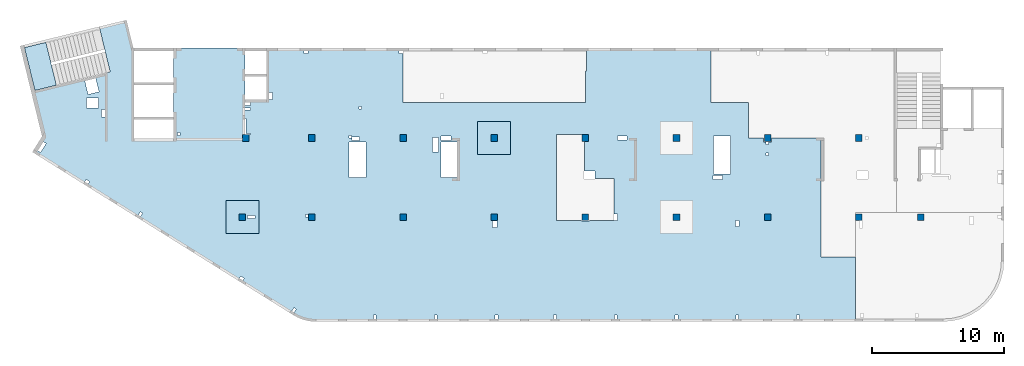
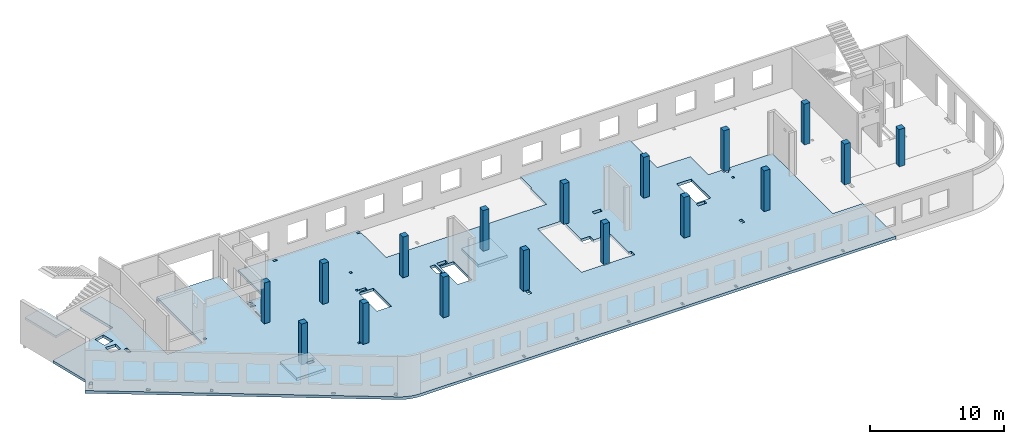
# One storey, part 1 of 6: 17 columns, 4 slabs.
"""IFC4 building model written with IfcOpenShell, lengths in millimetres."""

from ifc_helpers import new_model, entity, si_unit, converted_unit, derived_unit, direction, frame, origin, place, context, subcontext, project, spatial, indexed_curve, outline, extrude, source, transform, mapped, material, type_object, type_shapes, element, save


model = new_model("IFC4")

# Units and contexts
model_context = context("Model", 3, precision=0.01, world=origin(), true_north=direction((6.12303176911189e-17, 1.0)))
plan_context = context("Plan", 3, precision=0.01, world=origin(), true_north=direction((6.12303176911189e-17, 1.0)))
body_context = subcontext(model_context, "Body", "Model", "MODEL_VIEW")
ifc_project = project(units=[si_unit("LENGTHUNIT", "METRE", prefix="MILLI"), si_unit("AREAUNIT", "SQUARE_METRE"), si_unit("VOLUMEUNIT", "CUBIC_METRE"), converted_unit("PLANEANGLEUNIT", "DEGREE", entity("IfcRatioMeasure", 0.0174532925199433), si_unit("PLANEANGLEUNIT", "RADIAN"), dimensions=[0, 0, 0, 0, 0, 0, 0]), si_unit("MASSUNIT", "GRAM", prefix="KILO"), derived_unit("MASSDENSITYUNIT", [(si_unit("MASSUNIT", "GRAM", prefix="KILO"), 1), (si_unit("LENGTHUNIT", "METRE"), -3)]), derived_unit("MOMENTOFINERTIAUNIT", [(si_unit("LENGTHUNIT", "METRE"), 4)]), si_unit("TIMEUNIT", "SECOND"), si_unit("FREQUENCYUNIT", "HERTZ"), si_unit("THERMODYNAMICTEMPERATUREUNIT", "DEGREE_CELSIUS"), derived_unit("THERMALTRANSMITTANCEUNIT", [(si_unit("MASSUNIT", "GRAM", prefix="KILO"), 1), (si_unit("THERMODYNAMICTEMPERATUREUNIT", "KELVIN"), -1), (si_unit("TIMEUNIT", "SECOND"), -3)]), derived_unit("VOLUMETRICFLOWRATEUNIT", [(si_unit("LENGTHUNIT", "METRE"), 3), (si_unit("TIMEUNIT", "SECOND"), -1)]), derived_unit("MASSFLOWRATEUNIT", [(si_unit("MASSUNIT", "GRAM", prefix="KILO"), 1), (si_unit("TIMEUNIT", "SECOND"), -1)]), derived_unit("ROTATIONALFREQUENCYUNIT", [(si_unit("TIMEUNIT", "SECOND"), -1)]), si_unit("ELECTRICCURRENTUNIT", "AMPERE"), si_unit("ELECTRICVOLTAGEUNIT", "VOLT"), si_unit("POWERUNIT", "WATT"), si_unit("FORCEUNIT", "NEWTON", prefix="KILO"), si_unit("ILLUMINANCEUNIT", "LUX"), si_unit("LUMINOUSFLUXUNIT", "LUMEN"), si_unit("LUMINOUSINTENSITYUNIT", "CANDELA"), derived_unit("USERDEFINED", [(si_unit("MASSUNIT", "GRAM", prefix="KILO"), -1), (si_unit("LENGTHUNIT", "METRE"), -2), (si_unit("TIMEUNIT", "SECOND"), 3), (si_unit("LUMINOUSFLUXUNIT", "LUMEN"), 1)]), derived_unit("LINEARVELOCITYUNIT", [(si_unit("LENGTHUNIT", "METRE"), 1), (si_unit("TIMEUNIT", "SECOND"), -1)]), si_unit("PRESSUREUNIT", "PASCAL"), derived_unit("USERDEFINED", [(si_unit("LENGTHUNIT", "METRE"), -2), (si_unit("MASSUNIT", "GRAM", prefix="KILO"), 1), (si_unit("TIMEUNIT", "SECOND"), -2)]), derived_unit("LINEARFORCEUNIT", [(si_unit("MASSUNIT", "GRAM", prefix="KILO"), 1), (si_unit("LENGTHUNIT", "METRE"), 1), (si_unit("TIMEUNIT", "SECOND"), -2), (si_unit("LENGTHUNIT", "METRE"), -1)]), derived_unit("PLANARFORCEUNIT", [(si_unit("MASSUNIT", "GRAM", prefix="KILO"), 1), (si_unit("LENGTHUNIT", "METRE"), 1), (si_unit("TIMEUNIT", "SECOND"), -2), (si_unit("LENGTHUNIT", "METRE"), -2)])], contexts=[model_context, plan_context])

# Site, building, storey
site_placement = place(None, origin())
site = spatial("IfcSite", under=ifc_project, at=site_placement, CompositionType="ELEMENT")
building_placement = place(site_placement, origin())
building = spatial("IfcBuilding", under=site, at=building_placement, CompositionType="ELEMENT")
storey_placement = place(building_placement, frame((0.0, 0.0, 8100.0)))
storey = spatial("IfcBuildingStorey", under=building, at=storey_placement, Name="03", CompositionType="ELEMENT", Elevation=8100.0)

# Columns
ifc_material = material()
column_type_1 = type_object("IfcColumnType", PredefinedType="COLUMN", material=ifc_material)
shared_shape_1 = source(origin(), body_context, "Body", "SweptSolid", [
    extrude(outline(indexed_curve([(-249.999999999999, -249.999999999999), (250.000000000001, -249.999999999999), (249.999999999999, 249.999999999999), (-250.000000000001, 249.999999999999), (-249.999999999999, -249.999999999999)], self_intersect=False)), frame((15900.0, 7700.0, 7950.0), z_axis=(0.0, 0.0, 1.0), x_axis=(0.0, -1.0, 0.0)), (0.0, 0.0, 1.0), 3700.0),
])
type_shapes(column_type_1, [shared_shape_1])
placement_1 = place(storey_placement, frame((0.0, 0.0, -8100.0)))
element("IfcColumn", 1, at=placement_1, inside=storey, type_object=column_type_1, PredefinedType="COLUMN", context=body_context, shape_type="MappedRepresentation", body=[
    mapped(shared_shape_1, transform((0.0, 0.0, 0.0), scale=1.0)),
])
column_type_2 = type_object("IfcColumnType", PredefinedType="COLUMN", material=ifc_material)
shared_shape_2 = source(origin(), body_context, "Body", "SweptSolid", [
    extrude(outline(indexed_curve([(-249.999999999999, -249.999999999999), (250.000000000001, -249.999999999999), (249.999999999999, 249.999999999999), (-250.000000000001, 249.999999999999), (-249.999999999999, -249.999999999999)], self_intersect=False)), frame((21170.0, 7700.0, 7950.0), z_axis=(0.0, 0.0, 1.0), x_axis=(0.0, -1.0, 0.0)), (0.0, 0.0, 1.0), 3700.0),
])
type_shapes(column_type_2, [shared_shape_2])
element("IfcColumn", 2, at=placement_1, inside=storey, type_object=column_type_2, PredefinedType="COLUMN", context=body_context, shape_type="MappedRepresentation", body=[
    mapped(shared_shape_2, transform((0.0, 0.0, 0.0), scale=1.0)),
])
column_type_3 = type_object("IfcColumnType", PredefinedType="COLUMN", material=ifc_material)
shared_shape_3 = source(origin(), body_context, "Body", "SweptSolid", [
    extrude(outline(indexed_curve([(-249.999999999999, -249.999999999999), (250.000000000001, -249.999999999999), (250.000000000001, 249.999999999999), (-249.999999999999, 249.999999999999), (-249.999999999999, -249.999999999999)], self_intersect=False)), frame((28070.0, 7700.0, 7950.0), z_axis=(0.0, 0.0, 1.0), x_axis=(0.0, -1.0, 0.0)), (0.0, 0.0, 1.0), 3700.0),
])
type_shapes(column_type_3, [shared_shape_3])
element("IfcColumn", 3, at=placement_1, inside=storey, type_object=column_type_3, PredefinedType="COLUMN", context=body_context, shape_type="MappedRepresentation", body=[
    mapped(shared_shape_3, transform((0.0, 0.0, 0.0), scale=1.0)),
])
column_type_4 = type_object("IfcColumnType", PredefinedType="COLUMN", material=ifc_material)
shared_shape_4 = source(origin(), body_context, "Body", "SweptSolid", [
    extrude(outline(indexed_curve([(-249.999999999999, -249.999999999999), (250.000000000001, -249.999999999999), (249.999999999999, 249.999999999999), (-250.000000000001, 249.999999999999), (-249.999999999999, -249.999999999999)], self_intersect=False)), frame((34970.0, 7700.0, 7950.0), z_axis=(0.0, 0.0, 1.0), x_axis=(0.0, -1.0, 0.0)), (0.0, 0.0, 1.0), 3700.0),
])
type_shapes(column_type_4, [shared_shape_4])
element("IfcColumn", 4, at=placement_1, inside=storey, type_object=column_type_4, PredefinedType="COLUMN", context=body_context, shape_type="MappedRepresentation", body=[
    mapped(shared_shape_4, transform((0.0, 0.0, 0.0), scale=1.0)),
])
column_type_5 = type_object("IfcColumnType", PredefinedType="COLUMN", material=ifc_material)
shared_shape_5 = source(origin(), body_context, "Body", "SweptSolid", [
    extrude(outline(indexed_curve([(-249.999999999999, -250.000000000004), (250.000000000001, -250.000000000004), (250.000000000001, 249.999999999995), (-249.999999999999, 250.000000000004), (-249.999999999999, -250.000000000004)], self_intersect=False)), frame((41870.0, 7700.0, 7950.0), z_axis=(0.0, 0.0, 1.0), x_axis=(0.0, -1.0, 0.0)), (0.0, 0.0, 1.0), 3700.0),
])
type_shapes(column_type_5, [shared_shape_5])
element("IfcColumn", 5, at=placement_1, inside=storey, type_object=column_type_5, PredefinedType="COLUMN", context=body_context, shape_type="MappedRepresentation", body=[
    mapped(shared_shape_5, transform((0.0, 0.0, 0.0), scale=1.0)),
])
column_type_6 = type_object("IfcColumnType", PredefinedType="COLUMN", material=ifc_material)
shared_shape_6 = source(origin(), body_context, "Body", "SweptSolid", [
    extrude(outline(indexed_curve([(-249.999999999999, -250.000000000004), (250.000000000001, -250.000000000004), (249.999999999999, 249.999999999995), (-250.000000000001, 250.000000000004), (-249.999999999999, -250.000000000004)], self_intersect=False)), frame((48770.0, 7700.0, 7950.0), z_axis=(0.0, 0.0, 1.0), x_axis=(0.0, -1.0, 0.0)), (0.0, 0.0, 1.0), 3700.0),
])
type_shapes(column_type_6, [shared_shape_6])
element("IfcColumn", 6, at=placement_1, inside=storey, type_object=column_type_6, PredefinedType="COLUMN", context=body_context, shape_type="MappedRepresentation", body=[
    mapped(shared_shape_6, transform((0.0, 0.0, 0.0), scale=1.0)),
])
column_type_7 = type_object("IfcColumnType", PredefinedType="COLUMN", material=ifc_material)
shared_shape_7 = source(origin(), body_context, "Body", "SweptSolid", [
    extrude(outline(indexed_curve([(-249.999999999999, -250.000000000004), (250.000000000001, -250.000000000004), (250.000000000001, 249.999999999995), (-249.999999999999, 250.000000000004), (-249.999999999999, -250.000000000004)], self_intersect=False)), frame((55670.0, 7700.0, 7950.0), z_axis=(0.0, 0.0, 1.0), x_axis=(0.0, -1.0, 0.0)), (0.0, 0.0, 1.0), 3700.0),
])
type_shapes(column_type_7, [shared_shape_7])
element("IfcColumn", 7, at=placement_1, inside=storey, type_object=column_type_7, PredefinedType="COLUMN", context=body_context, shape_type="MappedRepresentation", body=[
    mapped(shared_shape_7, transform((0.0, 0.0, 0.0), scale=1.0)),
])
column_type_8 = type_object("IfcColumnType", PredefinedType="COLUMN", material=ifc_material)
shared_shape_8 = source(origin(), body_context, "Body", "SweptSolid", [
    extrude(outline(indexed_curve([(-249.999999999999, -250.000000000004), (250.000000000001, -250.000000000004), (249.999999999999, 249.999999999995), (-250.000000000001, 250.000000000004), (-249.999999999999, -250.000000000004)], self_intersect=False)), frame((62570.0, 7700.0, 7950.0), z_axis=(0.0, 0.0, 1.0), x_axis=(0.0, -1.0, 0.0)), (0.0, 0.0, 1.0), 3700.0),
])
type_shapes(column_type_8, [shared_shape_8])
element("IfcColumn", 8, at=placement_1, inside=storey, type_object=column_type_8, PredefinedType="COLUMN", context=body_context, shape_type="MappedRepresentation", body=[
    mapped(shared_shape_8, transform((0.0, 0.0, 0.0), scale=1.0)),
])
column_type_9 = type_object("IfcColumnType", PredefinedType="COLUMN", material=ifc_material)
shared_shape_9 = source(origin(), body_context, "Body", "SweptSolid", [
    extrude(outline(indexed_curve([(-249.999999999999, -250.000000000004), (250.000000000001, -250.000000000004), (249.999999999999, 249.999999999995), (-250.000000000001, 250.000000000004), (-249.999999999999, -250.000000000004)], self_intersect=False)), frame((67270.0, 7700.0, 7950.0), z_axis=(0.0, 0.0, 1.0), x_axis=(0.0, -1.0, 0.0)), (0.0, 0.0, 1.0), 3400.0),
])
type_shapes(column_type_9, [shared_shape_9])
element("IfcColumn", 9, at=placement_1, inside=storey, type_object=column_type_9, PredefinedType="COLUMN", context=body_context, shape_type="MappedRepresentation", body=[
    mapped(shared_shape_9, transform((0.0, 0.0, 0.0), scale=1.0)),
])
column_type_10 = type_object("IfcColumnType", PredefinedType="COLUMN", material=ifc_material)
shared_shape_10 = source(origin(), body_context, "Body", "SweptSolid", [
    extrude(outline(indexed_curve([(-249.999999999999, -250.000000000004), (249.999999999999, -250.000000000004), (249.999999999999, 249.999999999995), (-249.999999999999, 250.000000000004), (-249.999999999999, -250.000000000004)], self_intersect=False)), frame((62570.0, 13700.0, 7950.0), z_axis=(0.0, 0.0, 1.0), x_axis=(0.0, -1.0, 0.0)), (0.0, 0.0, 1.0), 3700.0),
])
type_shapes(column_type_10, [shared_shape_10])
element("IfcColumn", 10, at=placement_1, inside=storey, type_object=column_type_10, PredefinedType="COLUMN", context=body_context, shape_type="MappedRepresentation", body=[
    mapped(shared_shape_10, transform((0.0, 0.0, 0.0), scale=1.0)),
])
column_type_11 = type_object("IfcColumnType", PredefinedType="COLUMN", material=ifc_material)
shared_shape_11 = source(origin(), body_context, "Body", "SweptSolid", [
    extrude(outline(indexed_curve([(-249.999999999999, -250.000000000004), (249.999999999999, -250.000000000004), (249.999999999999, 249.999999999995), (-249.999999999999, 250.000000000004), (-249.999999999999, -250.000000000004)], self_intersect=False)), frame((55670.0, 13700.0, 7950.0), z_axis=(0.0, 0.0, 1.0), x_axis=(0.0, -1.0, 0.0)), (0.0, 0.0, 1.0), 3700.0),
])
type_shapes(column_type_11, [shared_shape_11])
element("IfcColumn", 11, at=placement_1, inside=storey, type_object=column_type_11, PredefinedType="COLUMN", context=body_context, shape_type="MappedRepresentation", body=[
    mapped(shared_shape_11, transform((0.0, 0.0, 0.0), scale=1.0)),
])
column_type_12 = type_object("IfcColumnType", PredefinedType="COLUMN", material=ifc_material)
shared_shape_12 = source(origin(), body_context, "Body", "SweptSolid", [
    extrude(outline(indexed_curve([(-249.999999999999, -250.000000000004), (249.999999999999, -250.000000000004), (249.999999999999, 249.999999999995), (-249.999999999999, 250.000000000004), (-249.999999999999, -250.000000000004)], self_intersect=False)), frame((48770.0, 13700.0, 7950.0), z_axis=(0.0, 0.0, 1.0), x_axis=(0.0, -1.0, 0.0)), (0.0, 0.0, 1.0), 3700.0),
])
type_shapes(column_type_12, [shared_shape_12])
element("IfcColumn", 12, at=placement_1, inside=storey, type_object=column_type_12, PredefinedType="COLUMN", context=body_context, shape_type="MappedRepresentation", body=[
    mapped(shared_shape_12, transform((0.0, 0.0, 0.0), scale=1.0)),
])
column_type_13 = type_object("IfcColumnType", PredefinedType="COLUMN", material=ifc_material)
shared_shape_13 = source(origin(), body_context, "Body", "SweptSolid", [
    extrude(outline(indexed_curve([(-249.999999999999, -250.000000000004), (249.999999999999, -250.000000000004), (249.999999999999, 249.999999999995), (-249.999999999999, 250.000000000004), (-249.999999999999, -250.000000000004)], self_intersect=False)), frame((41870.0, 13700.0, 7950.0), z_axis=(0.0, 0.0, 1.0), x_axis=(0.0, -1.0, 0.0)), (0.0, 0.0, 1.0), 3700.0),
])
type_shapes(column_type_13, [shared_shape_13])
element("IfcColumn", 13, at=placement_1, inside=storey, type_object=column_type_13, PredefinedType="COLUMN", context=body_context, shape_type="MappedRepresentation", body=[
    mapped(shared_shape_13, transform((0.0, 0.0, 0.0), scale=1.0)),
])
column_type_14 = type_object("IfcColumnType", PredefinedType="COLUMN", material=ifc_material)
shared_shape_14 = source(origin(), body_context, "Body", "SweptSolid", [
    extrude(outline(indexed_curve([(-249.999999999999, -249.999999999999), (249.999999999999, -249.999999999999), (249.999999999999, 249.999999999999), (-249.999999999999, 249.999999999999), (-249.999999999999, -249.999999999999)], self_intersect=False)), frame((34970.0, 13700.0, 7950.0), z_axis=(0.0, 0.0, 1.0), x_axis=(0.0, -1.0, 0.0)), (0.0, 0.0, 1.0), 3700.0),
])
type_shapes(column_type_14, [shared_shape_14])
element("IfcColumn", 14, at=placement_1, inside=storey, type_object=column_type_14, PredefinedType="COLUMN", context=body_context, shape_type="MappedRepresentation", body=[
    mapped(shared_shape_14, transform((0.0, 0.0, 0.0), scale=1.0)),
])
column_type_15 = type_object("IfcColumnType", PredefinedType="COLUMN", material=ifc_material)
shared_shape_15 = source(origin(), body_context, "Body", "SweptSolid", [
    extrude(outline(indexed_curve([(-249.999999999999, -249.999999999999), (249.999999999999, -249.999999999999), (249.999999999999, 249.999999999999), (-249.999999999999, 249.999999999999), (-249.999999999999, -249.999999999999)], self_intersect=False)), frame((28070.0, 13700.0, 7950.0), z_axis=(0.0, 0.0, 1.0), x_axis=(0.0, -1.0, 0.0)), (0.0, 0.0, 1.0), 3700.0),
])
type_shapes(column_type_15, [shared_shape_15])
element("IfcColumn", 15, at=placement_1, inside=storey, type_object=column_type_15, PredefinedType="COLUMN", context=body_context, shape_type="MappedRepresentation", body=[
    mapped(shared_shape_15, transform((0.0, 0.0, 0.0), scale=1.0)),
])
column_type_16 = type_object("IfcColumnType", PredefinedType="COLUMN", material=ifc_material)
shared_shape_16 = source(origin(), body_context, "Body", "SweptSolid", [
    extrude(outline(indexed_curve([(-249.999999999999, -249.999999999999), (249.999999999999, -249.999999999999), (249.999999999999, 249.999999999999), (-249.999999999999, 249.999999999999), (-249.999999999999, -249.999999999999)], self_intersect=False)), frame((21170.0, 13700.0, 7950.0), z_axis=(0.0, 0.0, 1.0), x_axis=(0.0, -1.0, 0.0)), (0.0, 0.0, 1.0), 3700.0),
])
type_shapes(column_type_16, [shared_shape_16])
element("IfcColumn", 16, at=placement_1, inside=storey, type_object=column_type_16, PredefinedType="COLUMN", context=body_context, shape_type="MappedRepresentation", body=[
    mapped(shared_shape_16, transform((0.0, 0.0, 0.0), scale=1.0)),
])
column_type_17 = type_object("IfcColumnType", PredefinedType="COLUMN", material=ifc_material)
shared_shape_17 = source(origin(), body_context, "Body", "SweptSolid", [
    extrude(outline(indexed_curve([(-249.999999999999, -249.999999999999), (249.999999999999, -249.999999999999), (249.999999999999, 249.999999999999), (-249.999999999999, 249.999999999999), (-249.999999999999, -249.999999999999)], self_intersect=False)), frame((16160.0, 13700.0, 7950.0), z_axis=(0.0, 0.0, 1.0), x_axis=(0.0, -1.0, 0.0)), (0.0, 0.0, 1.0), 3700.0),
])
type_shapes(column_type_17, [shared_shape_17])
element("IfcColumn", 17, at=placement_1, inside=storey, type_object=column_type_17, PredefinedType="COLUMN", context=body_context, shape_type="MappedRepresentation", body=[
    mapped(shared_shape_17, transform((0.0, 0.0, 0.0), scale=1.0)),
])

# Slabs
slab_type_1 = type_object("IfcSlabType", Name=":ADSK_ 25_250", PredefinedType="FLOOR", material=ifc_material)
placement_2 = place(storey_placement, origin())
element("IfcSlab", 18, at=placement_2, inside=storey, type_object=slab_type_1, material=ifc_material, Name=":ADSK_ 25_250", ObjectType=":ADSK_ 25_250", PredefinedType="FLOOR", context=body_context, shape_type="SweptSolid", body=[
    extrude(outline(indexed_curve([(-4918.44093092507, 21194.7161822057), (-4918.44093092504, 15794.7161822057), (-1018.44093092502, 15794.7161822057), (-1018.44093092502, 14169.7161822057), (-4918.44093092503, 14169.7161822057), (-4918.44093092499, 3824.71618220575), (-4718.44157029135, 3824.71618220575), (-4718.44157029135, 4124.71618220581), (-4518.44197312357, 4124.71618220581), (-4518.44197312357, 3824.71618220575), (-818.440930924992, 3824.71618220575), (-818.440930924947, -9975.28381779424), (-3198.44093092485, -9975.28381779424), (-3198.44093092485, -10075.2838177942), (-4918.44093092494, -10075.2838177942), (-4918.44093092491, -19495.2838177944), (-818.440930924876, -19495.2838177942), (-818.440930924728, -22325.2838177944), (1881.5590690752, -22325.2838177942), (1881.55906907526, -23475.2838177943), (2181.5590690751, -23475.2838177943), (2181.5590690751, -23650.2838177942), (2371.55802687642, -23650.2838177942), (2371.55802687642, -23850.2838177942), (2181.5590690751, -23850.2838177942), (2181.5590690751, -24075.2838177943), (1881.55906907526, -24075.2838177943), (1881.55906907527, -27835.2838177942), (10881.5590690753, -27835.2838177942), (10881.5590690753, -30425.2838177942), (15782.0128580296, -30425.2838177942), (15782.0128580296, 10427.6716031478), (15777.0106740912, 10606.4915509534), (15762.0197669795, 10784.7522260372), (15737.0870218744, 10961.8961048444), (15702.2904177954, 11137.3691566841), (15657.7387837167, 11310.6225765011), (15603.5714581962, 11481.1145013049), (15539.9578535838, 11648.3117048867), (15467.0969261719, 11811.691265524), (15385.2165539443, 11970.7422014573), (15294.5728238713, 12124.9670690234), (2942.09072966658, 31894.8565409199), (1763.37987869352, 31158.3306297265), (-1646.92724838292, 31989.6290722903), (-3108.1423640225, 25995.1605782929), (-6547.43664984333, 26833.5249474787), (-7051.87622791275, 24764.1190636373), (-4918.44093092509, 24244.0716386956), (-4918.44093092509, 24194.7161822057), (1931.55906907492, 24194.7161822058), (1931.55906907493, 21194.7161822057), (-4918.44093092507, 21194.7161822057)], self_intersect=False), holes=[indexed_curve([(1631.55906907515, -7800.28381779424), (7881.55906907513, -7800.28381779422), (8131.55906907513, -7800.28381779422), (8131.55906907513, -9675.28381779422), (8181.55906907513, -9675.28381779422), (8181.55906907513, -9975.28381779428), (8181.55906907513, -10275.2838177943), (8131.55906907513, -10275.2838177943), (8131.55802687643, -12400.2838177942), (7631.55802687644, -12400.2838177942), (7631.55802687644, -12150.2838177943), (4956.55906907508, -12150.2838177943), (4956.55906907509, -10690.2838177942), (4396.55906907515, -10690.2838177942), (4396.55906907515, -9925.28381779424), (2081.55906907572, -9925.28381779424), (2081.55906907572, -10225.2838177943), (1631.55906907515, -10225.2838177943), (1631.55906907515, -7800.28381779424)], self_intersect=False), indexed_curve([(-2433.4077366988, 27918.680956152), (-1413.3021088605, 27670.0194168614), (-1614.60687707192, 26844.1895456677), (-2634.71250491022, 27092.8510849583), (-2433.4077366988, 27918.680956152)], self_intersect=False), indexed_curve([(-1128.44197312358, 26884.7161822058), (-1128.44197312358, 27784.7161822058), (-388.441973123572, 27784.7161822058), (-388.441973123572, 26884.7161822058), (-1128.44197312358, 26884.7161822058)], self_intersect=False), indexed_curve([(-268.441973123565, 26394.7161822058), (-268.441973123565, 26644.7161822058), (291.558026876412, 26644.7161822058), (291.558026876412, 26394.7161822058), (-268.441973123565, 26394.7161822058)], self_intersect=False), indexed_curve([(2300.46693601222, 30845.3844889143), (2167.98706279423, 31057.4007421437), (2846.42925781629, 31481.3302032733), (2978.90913103428, 31269.313950044), (2300.46693601222, 30845.3844889143)], self_intersect=False), indexed_curve([(7467.44226277405, 23709.0856761198), (7721.85808590733, 23868.0592240434), (7827.84184543901, 23698.4464439791), (7573.42602230574, 23539.4728960555), (7467.44226277405, 23709.0856761198)], self_intersect=False), indexed_curve([(12496.324877766, 15849.7447590121), (12337.3522593331, 16104.1590946203), (12506.9628080886, 16210.1414599027), (12665.9354265215, 15955.7271242945), (12496.324877766, 15849.7447590121)], self_intersect=False), indexed_curve([(14729.8838440301, 12086.5228222013), (14984.2996671633, 12245.4963701249), (15090.283426695, 12075.8835900606), (14835.8676035617, 11916.910042137), (14729.8838440301, 12086.5228222013)], self_intersect=False), indexed_curve([(7731.55802687642, 15044.7161822058), (7731.55802687642, 15604.7161822058), (7981.55802687643, 15604.7161822058), (7981.55802687643, 15044.7161822058), (7731.55802687642, 15044.7161822058)], self_intersect=False), indexed_curve([(1481.55802687642, 20694.7161822058), (1481.55802687642, 20894.7161822058), (1681.55802687644, 20894.7161822058), (1681.55802687644, 20694.7161822058), (1481.55802687642, 20694.7161822058)], self_intersect=False), indexed_curve([(-818.440930924518, 15364.7161822058), (-818.440930924518, 15794.7161822057), (-568.441973123566, 15794.7161822057), (-568.441973123566, 15364.7161822058), (-818.440930924518, 15364.7161822058)], self_intersect=False), indexed_curve([(421.558026876417, 15714.7161822058), (421.558026876417, 15794.7161822057), (1611.55802687642, 15794.7161822057), (1611.55802687642, 15374.7161822058), (1531.55802687644, 15374.7161822058), (1531.55802687644, 15714.7161822058), (421.558026876417, 15714.7161822058)], self_intersect=False), indexed_curve([(-4718.44157029133, 11024.7161822058), (-4718.44157029133, 11324.7161822058), (-4518.44197312357, 11324.7161822058), (-4518.44197312357, 11024.7161822058), (-4718.44157029133, 11024.7161822058)], self_intersect=False), indexed_curve([(7681.55802687643, 11004.7161822058), (7681.55802687643, 11204.7161822058), (7881.559069075, 11204.7161822058), (7881.559069075, 11004.7161822058), (7681.55802687643, 11004.7161822058)], self_intersect=False), indexed_curve([(15281.5580268764, 5854.7161822058), (15281.5580268764, 6054.71618220579), (15581.5582512046, 6054.71618220579), (15581.5582512046, 5854.7161822058), (15281.5580268764, 5854.7161822058)], self_intersect=False), indexed_curve([(15581.5582512046, 1244.71651640657), (15281.5580268764, 1244.71651640657), (15281.5580268764, 1444.71651640656), (15581.5582512046, 1444.71651640656), (15581.5582512046, 1244.71651640657)], self_intersect=False), indexed_curve([(15581.5590690751, -3345.28348359343), (15281.5582857487, -3345.28348359343), (15281.5582857487, -3145.28348359344), (15581.5590690751, -3145.28348359344), (15581.5590690751, -3345.28348359343)], self_intersect=False), indexed_curve([(15581.5590690751, -7775.28381779419), (15281.5582857487, -7775.28381779419), (15281.5582857487, -7575.2838177942), (15581.5590690751, -7575.2838177942), (15581.5590690751, -7775.28381779419)], self_intersect=False), indexed_curve([(15581.5582512047, -12375.2834835934), (15281.5582857487, -12375.2834835934), (15281.5582857487, -12175.2834835934), (15581.5582512047, -12175.2834835934), (15581.5582512047, -12375.2834835934)], self_intersect=False), indexed_curve([(15581.5582512047, -16975.2838177942), (15281.5582857487, -16975.2838177942), (15281.5582857487, -16775.2838177942), (15581.5582512047, -16775.2838177942), (15581.5582512047, -16975.2838177942)], self_intersect=False), indexed_curve([(15281.5582857487, -21575.2834835934), (15281.5582857487, -21375.2834835934), (15581.5582512047, -21375.2834835934), (15581.5582512047, -21575.2834835934), (15281.5582857487, -21575.2834835934)], self_intersect=False), indexed_curve([(15281.5582857487, -26175.2834835934), (15281.5582857487, -25975.2834835934), (15581.5582512047, -25975.2834835934), (15581.5582512047, -26175.2834835934), (15281.5582857487, -26175.2834835934)], self_intersect=False), indexed_curve([(8581.55802687643, -21600.2838177942), (8131.55802687643, -21600.2838177942), (8131.55802687643, -21350.2838177942), (8581.55802687643, -21350.2838177942), (8581.55802687643, -21600.2838177942)], self_intersect=False), indexed_curve([(4731.55802687644, -20375.2838177942), (4731.55802687644, -19645.2838177942), (5031.55802687644, -19645.2838177942), (5031.55802687644, -20375.2838177942), (4731.55802687644, -20375.2838177942)], self_intersect=False), indexed_curve([(4606.55802687642, -20955.2838177942), (1746.55802687645, -20955.2838177942), (1746.55802687645, -19695.2838177942), (4606.55802687642, -19695.2838177942), (4606.55802687642, -20955.2838177942)], self_intersect=False), indexed_curve([(3001.55802687642, -23850.2838177942), (3001.55802687642, -23650.2838177942), (3201.55802687644, -23650.2838177942), (3201.55802687644, -23850.2838177942), (3001.55802687642, -23850.2838177942)], self_intersect=False), indexed_curve([(1741.55802687643, -13135.2838177942), (1741.55802687643, -12415.2838177942), (2031.55802687643, -12415.2838177942), (2031.55802687643, -13135.2838177942), (1741.55802687643, -13135.2838177942)], self_intersect=False), indexed_curve([(8641.55802687642, -3275.2838177942), (8181.55802687642, -3275.2838177942), (8181.55802687642, -2955.28381779421), (8641.55802687642, -2955.28381779421), (8641.55802687642, -3275.2838177942)], self_intersect=False), indexed_curve([(2181.55802687643, -275.283817794194), (2181.55802687643, 944.716182205806), (4891.55802687644, 944.716182205806), (4891.55802687644, -275.283817794194), (2181.55802687643, -275.283817794194)], self_intersect=False), indexed_curve([(2931.55802687644, 1144.7161822058), (1831.55802687644, 1144.7161822058), (1831.55802687644, 1604.71618220579), (2931.55802687644, 1604.71618220579), (2931.55802687644, 1144.7161822058)], self_intersect=False), indexed_curve([(1741.55802687643, 184.716182205805), (1741.55802687643, 944.716182205806), (2061.55802687643, 944.716182205806), (2061.55802687643, 184.716182205805), (1741.55802687643, 184.716182205805)], self_intersect=False), indexed_curve([(2181.55802687643, 6644.71618220579), (2181.55802687643, 7904.71618220578), (4891.55802687644, 7904.71618220578), (4891.55802687644, 6644.71618220579), (2181.55802687643, 6644.71618220579)], self_intersect=False), indexed_curve([(1691.55802687644, 7724.71618220579), (1691.55802687644, 7924.71618220581), (1891.55802687643, 7924.71618220581), (1891.55802687643, 7724.71618220579), (1691.55802687644, 7724.71618220579)], self_intersect=False), indexed_curve([(1811.55802687641, 7124.71618220579), (1811.55802687641, 7684.7161822058), (2061.55802687643, 7684.7161822058), (2061.55802687643, 7124.71618220579), (1811.55802687641, 7124.71618220579)], self_intersect=False), indexed_curve([(-518.441973123577, 6974.71618220579), (-518.441973123577, 7174.71618220581), (-318.441973123588, 7174.71618220581), (-318.441973123588, 6974.71618220579), (-518.441973123577, 6974.71618220579)], self_intersect=False), indexed_curve([(-393.441973123588, 15794.7161822058), (-233.441973123555, 15794.7161822058), (-233.441973123555, 15364.7161822058), (-393.441973123588, 15364.7161822058), (-393.441973123588, 15794.7161822058)], self_intersect=False), indexed_curve([(-1578.44197312358, 13969.7161822057), (-1018.44093092451, 13969.7161822057), (-1018.44093092451, 13719.7161822059), (-1578.44197312358, 13719.7161822059), (-1578.44197312358, 13969.7161822057)], self_intersect=False), indexed_curve([(5194.17744481265, 27913.2727788869), (5353.15222175436, 27658.8549888751), (5183.35238030296, 27552.7543426969), (5024.37760336126, 27807.1721327087), (5194.17744481265, 27913.2727788869)], self_intersect=False)]), frame((31894.72, 15581.56, -400.0), z_axis=(0.0, 0.0, -1.0), x_axis=(0.0, -1.0, 0.0)), (0.0, 0.0, -1.0), 249.999999999999),
])
slab_type_2 = type_object("IfcSlabType", Name=":ADSK_ 25_250", PredefinedType="FLOOR", material=ifc_material)
element("IfcSlab", 19, at=placement_2, inside=storey, type_object=slab_type_2, material=ifc_material, Name=":ADSK_ 25_250", ObjectType=":ADSK_ 25_250", PredefinedType="FLOOR", context=body_context, shape_type="SweptSolid", body=[
    extrude(outline(indexed_curve([(-1250.0, -1250.0), (1250.0, -1250.0), (1250.0, 1250.0), (-1250.0, 1250.0), (-1250.0, -1250.0)], self_intersect=False), holes=[indexed_curve([(-949.999999999979, -150.001042198552), (-949.999999999979, 99.9989578014607), (-389.999999999968, 99.9989578014607), (-389.999999999968, -150.001042198552), (-949.999999999979, -150.001042198552)], self_intersect=False)]), frame((15900.0, 7700.0, -650.0), z_axis=(0.0, 0.0, 1.0), x_axis=(-1.0, 0.0, 0.0)), (0.0, 0.0, 1.0), 250.000000000001),
])
slab_type_3 = type_object("IfcSlabType", Name=":ADSK_ 25_250", PredefinedType="FLOOR", material=ifc_material)
element("IfcSlab", 20, at=placement_2, inside=storey, type_object=slab_type_3, material=ifc_material, Name=":ADSK_ 25_250", ObjectType=":ADSK_ 25_250", PredefinedType="FLOOR", context=body_context, shape_type="SweptSolid", body=[
    extrude(outline(indexed_curve([(-1250.0, -1249.99999999999), (1250.0, -1249.99999999999), (1250.0, 1250.0), (-1250.0, 1250.0), (-1250.0, -1249.99999999999)], self_intersect=False)), frame((34970.0, 13700.0, -400.0), z_axis=(0.0, 0.0, -1.0), x_axis=(0.0, 1.0, 0.0)), (0.0, 0.0, 1.0), 250.000000000001),
])
slab_type_4 = type_object("IfcSlabType", Name=":ADSK_ 25_200", PredefinedType="FLOOR", material=ifc_material)
element("IfcSlab", 21, at=placement_2, inside=storey, type_object=slab_type_4, material=ifc_material, Name=":ADSK_ 25_200", ObjectType=":ADSK_ 25_200", PredefinedType="FLOOR", context=body_context, shape_type="SweptSolid", body=[
    extrude(outline(indexed_curve([(-835.0, -1670.00000000002), (835.0, -1670.00000000002), (835.0, 1670.00000000002), (-835.000000000001, 1670.00000000002), (-835.0, -1670.00000000002)], self_intersect=False)), frame((612.3, 19119.78, 1920.0), z_axis=(0.0, 0.0, -1.0), x_axis=(0.971552058141474, 0.236826092990333, 0.0)), (0.0, 0.0, 1.0), 200.0),
])

save(model, "model.ifc")
